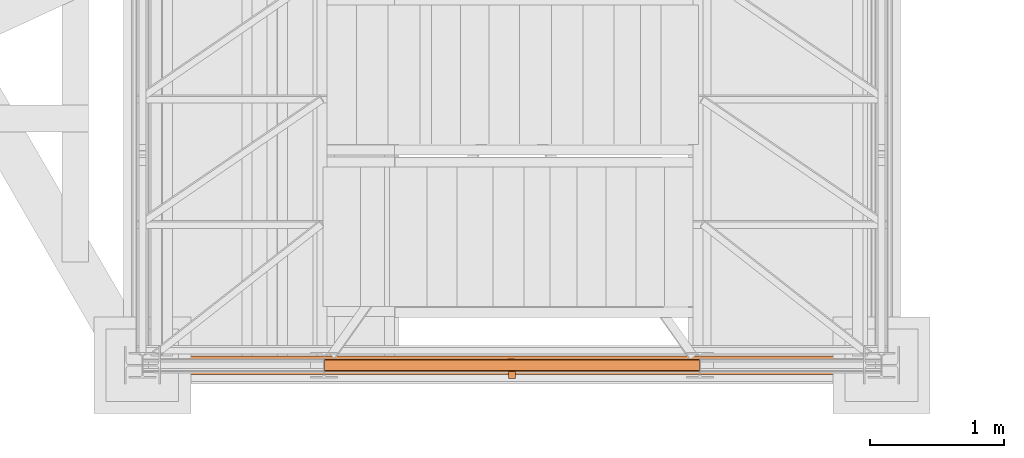
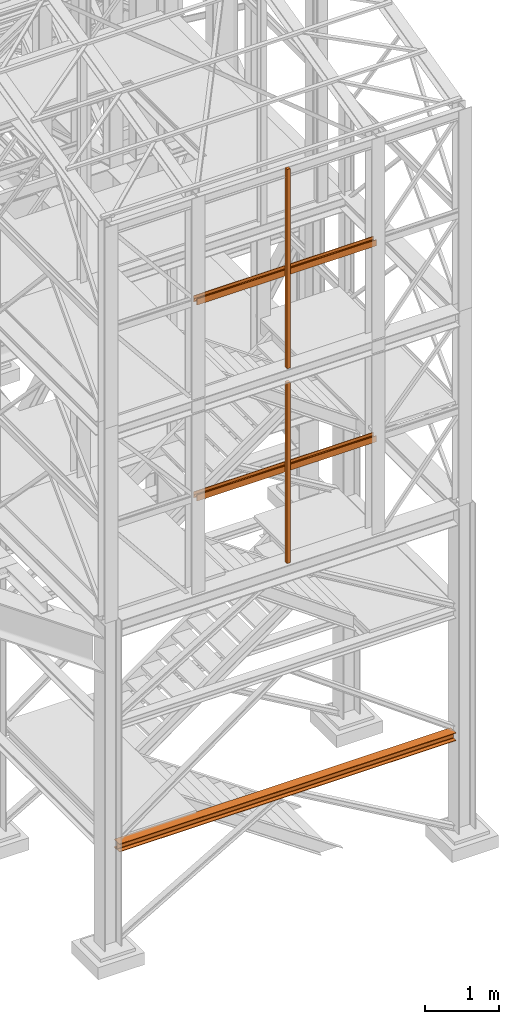
# One storey, part 40 of 208: 7 proxies.
"""IFC2X3 building model written with IfcOpenShell, lengths in millimetres."""

import ifcopenshell
import ifcopenshell.guid

model = None  # the IFC model being written
_history = None  # IfcOwnerHistory: only IFC2X3 demands one
_inside = {}  # id of a spatial element -> (the spatial element, [elements in it])
_under = {}  # id of a project, library or spatial element -> (it, [spatial elements below it])
_declared = {}  # id of a project -> (the project, [libraries it declares])
_typed = {}  # id of a type object -> (the type object, [elements of that type])
_made_of = {}  # id of a material, layer set ... -> (it, [elements and type objects made of it])


def new_model(schema):
    """Start an empty IFC model of exactly this schema.

    Asked for "IFC4X3", IfcOpenShell would pick the latest addendum, in which some entities
    have other attributes; the version numbers below select the first issue.
    IFC2X3 requires an IfcOwnerHistory on every rooted entity: one is made here for all.
    """
    global model, _history
    if schema == "IFC4X3":
        model = ifcopenshell.file(schema_version=(4, 3, 0, 0))
    else:
        model = ifcopenshell.file(schema=schema)
    _inside.clear()
    _under.clear()
    _declared.clear()
    _typed.clear()
    _made_of.clear()
    _history = None
    if model.schema == "IFC2X3":
        org = make("IfcOrganization", Name="unknown")
        user = make(
            "IfcPersonAndOrganization",
            ThePerson=make("IfcPerson", FamilyName="unknown"),
            TheOrganization=org,
        )
        app = make(
            "IfcApplication",
            ApplicationDeveloper=org,
            Version="unknown",
            ApplicationFullName="unknown",
            ApplicationIdentifier="unknown",
        )
        _history = make(
            "IfcOwnerHistory",
            OwningUser=user,
            OwningApplication=app,
            ChangeAction="ADDED",
            CreationDate=0,
        )
    return model


def make(cls, **values):
    """One entity of the class cls with the attributes given. An attribute that is None is left unset."""
    return model.create_entity(
        cls, **{name: value for name, value in values.items() if value is not None}
    )


def entity(cls, *values):
    """Any entity or typed value of the class cls, its attributes in the order of the schema. None: left unset."""
    e = model.create_entity(cls)
    for i, value in enumerate(values):
        if value is not None:
            e[i] = value
    return e


def rooted(cls, **values):
    """An entity with a GlobalId (a new one), such as an element, a storey or a relation."""
    return make(cls, GlobalId=ifcopenshell.guid.new(), OwnerHistory=_history, **values)


def si_unit(unit_type, name, prefix=None):
    """IfcSIUnit, for example si_unit("LENGTHUNIT", "METRE", prefix="MILLI")."""
    return make("IfcSIUnit", UnitType=unit_type, Prefix=prefix, Name=name)


def converted_unit(unit_type, name, factor, base, dimensions=None, offset=None):
    """IfcConversionBasedUnit, such as the inch: factor (a typed value) times the base unit."""
    return make(
        "IfcConversionBasedUnit"
        if offset is None
        else "IfcConversionBasedUnitWithOffset",
        ConversionOffset=offset,
        Dimensions=None
        if dimensions is None
        else entity("IfcDimensionalExponents", *dimensions),
        UnitType=unit_type,
        Name=name,
        ConversionFactor=make(
            "IfcMeasureWithUnit", ValueComponent=factor, UnitComponent=base
        ),
    )


def assignment(units):
    """IfcUnitAssignment: the units of a project."""
    return None if units is None else make("IfcUnitAssignment", Units=units)


def point(xyz):
    """IfcCartesianPoint."""
    return None if xyz is None else make("IfcCartesianPoint", Coordinates=xyz)


def direction(xyz):
    """IfcDirection."""
    return None if xyz is None else make("IfcDirection", DirectionRatios=xyz)


def frame(location, z_axis=None, x_axis=None):
    """IfcAxis2Placement3D, a coordinate frame: its origin and axes. An axis left out is left unset."""
    return make(
        "IfcAxis2Placement3D",
        Location=point(location),
        Axis=direction(z_axis),
        RefDirection=direction(x_axis),
    )


def origin():
    """The frame at (0, 0, 0) with its axes left unset."""
    return frame((0.0, 0.0, 0.0))


def origin_with_axes():
    """The frame at (0, 0, 0) with the z axis (0, 0, 1) and the x axis (1, 0, 0) written out."""
    return frame((0.0, 0.0, 0.0), z_axis=(0.0, 0.0, 1.0), x_axis=(1.0, 0.0, 0.0))


def place(relative_to, where):
    """IfcLocalPlacement: puts the frame where relative to a parent placement (None: the world)."""
    return make(
        "IfcLocalPlacement", PlacementRelTo=relative_to, RelativePlacement=where
    )


def context(
    kind, dimensions, precision=None, world=None, true_north=None, identifier=None
):
    """IfcGeometricRepresentationContext, for example the 3D "Model" context."""
    return make(
        "IfcGeometricRepresentationContext",
        ContextIdentifier=identifier,
        ContextType=kind,
        CoordinateSpaceDimension=dimensions,
        Precision=precision,
        WorldCoordinateSystem=world,
        TrueNorth=true_north,
    )


def subcontext(parent, identifier, kind, view, scale=None):
    """IfcGeometricRepresentationSubContext, for example "Body" below "Model"."""
    return make(
        "IfcGeometricRepresentationSubContext",
        ContextIdentifier=identifier,
        ContextType=kind,
        ParentContext=parent,
        TargetScale=scale,
        TargetView=view,
    )


def project(units=None, contexts=None):
    """IfcProject with its units and contexts."""
    return rooted(
        "IfcProject",
        Name="project",
        RepresentationContexts=contexts,
        UnitsInContext=assignment(units),
    )


def spatial(cls, under=None, at=None, **own):
    """A site, building, storey or space (cls), placed at a placement, below another one or the project."""
    s = rooted(cls, ObjectPlacement=at, **own)
    if under is not None:
        _under.setdefault(under.id(), (under, []))[1].append(s)
    return s


def faces_of(points, faces, orient=None, outer=None):
    """IfcFace entities. A face is a list of loops; a loop is a list of indices into points, from 0.

    orient and outer hold one flag for each loop. By default every Orientation is true, the
    first loop of a face is its IfcFaceOuterBound and the others are IfcFaceBound.
    """
    made = []
    for i, loops in enumerate(faces):
        bounds = []
        for j, loop in enumerate(loops):
            is_outer = j == 0 if outer is None else outer[i][j]
            bounds.append(
                make(
                    "IfcFaceOuterBound" if is_outer else "IfcFaceBound",
                    Bound=make("IfcPolyLoop", Polygon=[points[k] for k in loop]),
                    Orientation=True if orient is None else orient[i][j],
                )
            )
        made.append(make("IfcFace", Bounds=bounds))
    return made


def faceted_brep(points, faces, orient=None, outer=None, voids=None):
    """IfcFacetedBrep: a solid bounded by flat faces; with voids (closed shells), ...WithVoids."""
    shared = [point(p) for p in points]
    hull = make("IfcClosedShell", CfsFaces=faces_of(shared, faces, orient, outer))
    if voids is None:
        return make("IfcFacetedBrep", Outer=hull)
    return make(
        "IfcFacetedBrepWithVoids",
        Outer=hull,
        Voids=[
            make(cls, CfsFaces=faces_of(shared, fs, o, b)) for cls, fs, o, b in voids
        ],
    )


def shape(context_of_items, identifier, shape_type, items):
    """IfcShapeRepresentation: the items that make up one representation, for example the "Body"."""
    return make(
        "IfcShapeRepresentation",
        ContextOfItems=context_of_items,
        RepresentationIdentifier=identifier,
        RepresentationType=shape_type,
        Items=items,
    )


def made_of(thing, what):
    """Note that an element or type object is made of a material, layer set ...; save() writes the relation."""
    if what is not None:
        _made_of.setdefault(what.id(), (what, []))[1].append(thing)
    return thing


def element(
    cls,
    number,
    at=None,
    inside=None,
    cuts=None,
    type_object=None,
    material=None,
    context=None,
    identifier="Body",
    shape_type=None,
    held_by="IfcProductDefinitionShape",
    body=None,
    shapes=None,
    **own,
):
    """One element of the class cls, such as IfcWall. Its Tag is "e" and its number.

    at: its placement. inside: the storey or other place that contains it. cuts: it is an
    opening in that element (IfcRelVoidsElement). A single representation is given by context,
    identifier, shape_type and body (its items); several are given by shapes. held_by: the class
    of the entity that holds the representations. save() writes the other relations.
    """
    e = rooted(cls, Tag="e%d" % number, ObjectPlacement=at, **own)
    if body is not None:
        shapes = [shape(context, identifier, shape_type, body)]
    if shapes is not None:
        e.Representation = make(held_by, Representations=shapes)
    if inside is not None:
        _inside.setdefault(inside.id(), (inside, []))[1].append(e)
    if cuts is not None:
        rooted(
            "IfcRelVoidsElement", RelatingBuildingElement=cuts, RelatedOpeningElement=e
        )
    if type_object is not None:
        _typed.setdefault(type_object.id(), (type_object, []))[1].append(e)
    return made_of(e, material)


def aggregate(whole, parts):
    """IfcRelAggregates: a whole, such as a stair, and the parts it consists of."""
    return rooted("IfcRelAggregates", RelatingObject=whole, RelatedObjects=parts)


def save(model, path):
    """Write the relations noted so far, then the file.

    IfcRelAggregates (storeys below a building ...), IfcRelContainedInSpatialStructure (elements
    in a storey), IfcRelDefinesByType, IfcRelAssociatesMaterial and IfcRelDeclares: one each for
    every whole, place, type object, material and project.
    """
    for whole, parts in _under.values():
        aggregate(whole, parts)
    for where, things in _inside.values():
        rooted(
            "IfcRelContainedInSpatialStructure",
            RelatedElements=things,
            RelatingStructure=where,
        )
    for kind, things in _typed.values():
        rooted("IfcRelDefinesByType", RelatedObjects=things, RelatingType=kind)
    for what, things in _made_of.values():
        rooted("IfcRelAssociatesMaterial", RelatedObjects=things, RelatingMaterial=what)
    for by, libraries in _declared.values():
        rooted("IfcRelDeclares", RelatingContext=by, RelatedDefinitions=libraries)
    model.write(path)


model = new_model("IFC2X3")

# Units and contexts
model_context = context("Model", 3, precision=1e-05, world=origin())
plan_context = context("Plan", 3, precision=1e-05, world=origin())
body_context = subcontext(model_context, "Body", "Model", "MODEL_VIEW")
ifc_project = project(units=[si_unit("LENGTHUNIT", "METRE", prefix="MILLI"), converted_unit("PLANEANGLEUNIT", "DEGREE", entity("IfcPlaneAngleMeasure", 0.0174532925199433), si_unit("PLANEANGLEUNIT", "RADIAN"), dimensions=[0, 0, 0, 0, 0, 0, 0]), si_unit("AREAUNIT", "SQUARE_METRE"), si_unit("VOLUMEUNIT", "CUBIC_METRE")], contexts=[model_context, plan_context])

# Building, storey
building_placement = place(None, origin())
building = spatial("IfcBuilding", under=ifc_project, at=building_placement, CompositionType="COMPLEX")
storey_placement = place(building_placement, origin_with_axes())
storey = spatial("IfcBuildingStorey", under=building, at=storey_placement, Name="Geschoss", CompositionType="ELEMENT")

# Proxies
proxy_1_placement = place(storey_placement, frame((2551.504968595716, -25220.57439031787, 9979.990000745052), z_axis=(0.0, 0.0, 1.0), x_axis=(1.0, 0.0, 0.0)))
element("IfcBuildingElementProxy", 1, at=proxy_1_placement, inside=storey, context=body_context, shape_type="Brep", body=[
    faceted_brep([(0.01000000000021828, 8.0099999999984, 0.01000000000021828), (0.01000000000021828, 8.0099999999984, 47.51000000000022), (0.01000000000021828, 88.0099999999984, 47.51000000000022), (0.01000000000021828, 88.0099999999984, 0.01000000000021828), (0.01000000000021828, 96.0099999999984, 0.01000000000021828), (0.01000000000021828, 96.0099999999984, 100.0100000000002), (0.01000000000021828, 88.0099999999984, 100.0100000000002), (0.01000000000021828, 88.0099999999984, 52.51000000000022), (0.01000000000021828, 8.0099999999984, 52.51000000000022), (0.01000000000021828, 8.0099999999984, 100.0100000000002), (0.01000000000021828, 0.00999999999839929, 100.0100000000002), (0.01000000000021828, 0.00999999999839929, 0.01000000000021828), (0.01000000000021828, 0.00999999999839929, 0.01000000000021828), (2793.509999865888, 0.00999999999839929, 0.01000000000021828), (2793.509999865888, 8.0099999999984, 0.01000000000021828), (0.01000000000021828, 8.0099999999984, 0.01000000000021828), (0.01000000000021828, 0.00999999999839929, 100.0100000000002), (2793.509999865888, 0.00999999999839929, 100.0100000000002), (2793.509999865888, 0.00999999999839929, 0.01000000000021828), (0.01000000000021828, 0.00999999999839929, 0.01000000000021828), (0.01000000000021828, 8.0099999999984, 100.0100000000002), (2793.509999865888, 8.0099999999984, 100.0100000000002), (2793.509999865888, 0.00999999999839929, 100.0100000000002), (0.01000000000021828, 0.00999999999839929, 100.0100000000002), (0.01000000000021828, 8.0099999999984, 52.51000000000022), (2793.509999865888, 8.0099999999984, 52.51000000000022), (2793.509999865888, 8.0099999999984, 100.0100000000002), (0.01000000000021828, 8.0099999999984, 100.0100000000002), (0.01000000000021828, 88.0099999999984, 52.51000000000022), (2793.509999865888, 88.0099999999984, 52.51000000000022), (2793.509999865888, 8.0099999999984, 52.51000000000022), (0.01000000000021828, 8.0099999999984, 52.51000000000022), (0.01000000000021828, 88.0099999999984, 100.0100000000002), (2793.509999865888, 88.0099999999984, 100.0100000000002), (2793.509999865888, 88.0099999999984, 52.51000000000022), (0.01000000000021828, 88.0099999999984, 52.51000000000022), (0.01000000000021828, 96.0099999999984, 100.0100000000002), (2793.509999865888, 96.0099999999984, 100.0100000000002), (2793.509999865888, 88.0099999999984, 100.0100000000002), (0.01000000000021828, 88.0099999999984, 100.0100000000002), (0.01000000000021828, 96.0099999999984, 0.01000000000021828), (2793.509999865888, 96.0099999999984, 0.01000000000021828), (2793.509999865888, 96.0099999999984, 100.0100000000002), (0.01000000000021828, 96.0099999999984, 100.0100000000002), (0.01000000000021828, 88.0099999999984, 0.01000000000021828), (2793.509999865888, 88.0099999999984, 0.01000000000021828), (2793.509999865888, 96.0099999999984, 0.01000000000021828), (0.01000000000021828, 96.0099999999984, 0.01000000000021828), (0.01000000000021828, 88.0099999999984, 47.51000000000022), (2793.509999865888, 88.0099999999984, 47.51000000000022), (2793.509999865888, 88.0099999999984, 0.01000000000021828), (0.01000000000021828, 88.0099999999984, 0.01000000000021828), (0.01000000000021828, 8.0099999999984, 47.51000000000022), (2793.509999865888, 8.0099999999984, 47.51000000000022), (2793.509999865888, 88.0099999999984, 47.51000000000022), (0.01000000000021828, 88.0099999999984, 47.51000000000022), (0.01000000000021828, 8.0099999999984, 0.01000000000021828), (2793.509999865888, 8.0099999999984, 0.01000000000021828), (2793.509999865888, 8.0099999999984, 47.51000000000022), (0.01000000000021828, 8.0099999999984, 47.51000000000022), (2793.509999865888, 8.0099999999984, 0.01000000000021828), (2793.509999865888, 0.00999999999839929, 0.01000000000021828), (2793.509999865888, 0.00999999999839929, 100.0100000000002), (2793.509999865888, 8.0099999999984, 100.0100000000002), (2793.509999865888, 8.0099999999984, 52.51000000000022), (2793.509999865888, 88.0099999999984, 52.51000000000022), (2793.509999865888, 88.0099999999984, 100.0100000000002), (2793.509999865888, 96.0099999999984, 100.0100000000002), (2793.509999865888, 96.0099999999984, 0.01000000000021828), (2793.509999865888, 88.0099999999984, 0.01000000000021828), (2793.509999865888, 88.0099999999984, 47.51000000000022), (2793.509999865888, 8.0099999999984, 47.51000000000022)], [[[0, 1, 2, 3, 4, 5, 6, 7, 8, 9, 10, 11]], [[12, 13, 14, 15]], [[16, 17, 18, 19]], [[20, 21, 22, 23]], [[24, 25, 26, 27]], [[28, 29, 30, 31]], [[32, 33, 34, 35]], [[36, 37, 38, 39]], [[40, 41, 42, 43]], [[44, 45, 46, 47]], [[48, 49, 50, 51]], [[52, 53, 54, 55]], [[56, 57, 58, 59]], [[60, 61, 62, 63, 64, 65, 66, 67, 68, 69, 70, 71]]], orient=[[False], [False], [False], [False], [False], [False], [False], [False], [False], [False], [False], [False], [False], [False]]),
])
proxy_2_placement = place(storey_placement, frame((3923.254968156133, -25270.57439106293, 8484.990002086157), z_axis=(0.0, 0.0, 1.0), x_axis=(1.0, 0.0, 0.0)))
element("IfcBuildingElementProxy", 2, at=proxy_2_placement, inside=storey, context=body_context, shape_type="Brep", body=[
    faceted_brep([(50.01000074505828, 0.00999999999839929, 0.01000000000021828), (50.01000074505828, 50.01000074505646, 0.01000000000021828), (0.01000000000021828, 50.01000074505646, 0.01000000000021828), (0.01000000000021828, 0.00999999999839929, 0.01000000000021828), (50.01000074505828, 50.01000074505646, 3275.010003576283), (50.01000074505828, 0.00999999999839929, 3275.010003576283), (0.01000000000021828, 0.00999999999839929, 3275.010003576283), (0.01000000000021828, 50.01000074505646, 3275.010003576283), (50.01000074505828, 50.01000074505646, 0.01000000000021828), (50.01000074505828, 0.00999999999839929, 0.01000000000021828), (50.01000074505828, 0.00999999999839929, 3275.010003576283), (50.01000074505828, 50.01000074505646, 3275.010003576283), (0.01000000000021828, 50.01000074505646, 0.01000000000021828), (50.01000074505828, 50.01000074505646, 0.01000000000021828), (50.01000074505828, 50.01000074505646, 3275.010003576283), (0.01000000000021828, 50.01000074505646, 3275.010003576283), (0.01000000000021828, 0.00999999999839929, 0.01000000000021828), (0.01000000000021828, 50.01000074505646, 0.01000000000021828), (0.01000000000021828, 50.01000074505646, 3275.010003576283), (0.01000000000021828, 0.00999999999839929, 3275.010003576283), (50.01000074505828, 0.00999999999839929, 0.01000000000021828), (0.01000000000021828, 0.00999999999839929, 0.01000000000021828), (0.01000000000021828, 0.00999999999839929, 3275.010003576283), (50.01000074505828, 0.00999999999839929, 3275.010003576283)], [[[0, 1, 2, 3]], [[4, 5, 6, 7]], [[8, 9, 10, 11]], [[12, 13, 14, 15]], [[16, 17, 18, 19]], [[20, 21, 22, 23]]], orient=[[False], [False], [False], [False], [False], [False]]),
])
proxy_3_placement = place(storey_placement, frame((2551.504968595716, -25220.57439031787, 9979.990000745052), z_axis=(0.0, 0.0, 1.0), x_axis=(1.0, 0.0, 0.0)))
element("IfcBuildingElementProxy", 3, at=proxy_3_placement, inside=storey, context=body_context, shape_type="Brep", body=[
    faceted_brep([(0.01000000000021828, 8.0099999999984, 0.01000000000021828), (0.01000000000021828, 8.0099999999984, 47.51000000000022), (0.01000000000021828, 88.0099999999984, 47.51000000000022), (0.01000000000021828, 88.0099999999984, 0.01000000000021828), (0.01000000000021828, 96.0099999999984, 0.01000000000021828), (0.01000000000021828, 96.0099999999984, 100.0100000000002), (0.01000000000021828, 88.0099999999984, 100.0100000000002), (0.01000000000021828, 88.0099999999984, 52.51000000000022), (0.01000000000021828, 8.0099999999984, 52.51000000000022), (0.01000000000021828, 8.0099999999984, 100.0100000000002), (0.01000000000021828, 0.00999999999839929, 100.0100000000002), (0.01000000000021828, 0.00999999999839929, 0.01000000000021828), (0.01000000000021828, 0.00999999999839929, 0.01000000000021828), (2793.509999865888, 0.00999999999839929, 0.01000000000021828), (2793.509999865888, 8.0099999999984, 0.01000000000021828), (0.01000000000021828, 8.0099999999984, 0.01000000000021828), (0.01000000000021828, 0.00999999999839929, 100.0100000000002), (2793.509999865888, 0.00999999999839929, 100.0100000000002), (2793.509999865888, 0.00999999999839929, 0.01000000000021828), (0.01000000000021828, 0.00999999999839929, 0.01000000000021828), (0.01000000000021828, 8.0099999999984, 100.0100000000002), (2793.509999865888, 8.0099999999984, 100.0100000000002), (2793.509999865888, 0.00999999999839929, 100.0100000000002), (0.01000000000021828, 0.00999999999839929, 100.0100000000002), (0.01000000000021828, 8.0099999999984, 52.51000000000022), (2793.509999865888, 8.0099999999984, 52.51000000000022), (2793.509999865888, 8.0099999999984, 100.0100000000002), (0.01000000000021828, 8.0099999999984, 100.0100000000002), (0.01000000000021828, 88.0099999999984, 52.51000000000022), (2793.509999865888, 88.0099999999984, 52.51000000000022), (2793.509999865888, 8.0099999999984, 52.51000000000022), (0.01000000000021828, 8.0099999999984, 52.51000000000022), (0.01000000000021828, 88.0099999999984, 100.0100000000002), (2793.509999865888, 88.0099999999984, 100.0100000000002), (2793.509999865888, 88.0099999999984, 52.51000000000022), (0.01000000000021828, 88.0099999999984, 52.51000000000022), (0.01000000000021828, 96.0099999999984, 100.0100000000002), (2793.509999865888, 96.0099999999984, 100.0100000000002), (2793.509999865888, 88.0099999999984, 100.0100000000002), (0.01000000000021828, 88.0099999999984, 100.0100000000002), (0.01000000000021828, 96.0099999999984, 0.01000000000021828), (2793.509999865888, 96.0099999999984, 0.01000000000021828), (2793.509999865888, 96.0099999999984, 100.0100000000002), (0.01000000000021828, 96.0099999999984, 100.0100000000002), (0.01000000000021828, 88.0099999999984, 0.01000000000021828), (2793.509999865888, 88.0099999999984, 0.01000000000021828), (2793.509999865888, 96.0099999999984, 0.01000000000021828), (0.01000000000021828, 96.0099999999984, 0.01000000000021828), (0.01000000000021828, 88.0099999999984, 47.51000000000022), (2793.509999865888, 88.0099999999984, 47.51000000000022), (2793.509999865888, 88.0099999999984, 0.01000000000021828), (0.01000000000021828, 88.0099999999984, 0.01000000000021828), (0.01000000000021828, 8.0099999999984, 47.51000000000022), (2793.509999865888, 8.0099999999984, 47.51000000000022), (2793.509999865888, 88.0099999999984, 47.51000000000022), (0.01000000000021828, 88.0099999999984, 47.51000000000022), (0.01000000000021828, 8.0099999999984, 0.01000000000021828), (2793.509999865888, 8.0099999999984, 0.01000000000021828), (2793.509999865888, 8.0099999999984, 47.51000000000022), (0.01000000000021828, 8.0099999999984, 47.51000000000022), (2793.509999865888, 8.0099999999984, 0.01000000000021828), (2793.509999865888, 0.00999999999839929, 0.01000000000021828), (2793.509999865888, 0.00999999999839929, 100.0100000000002), (2793.509999865888, 8.0099999999984, 100.0100000000002), (2793.509999865888, 8.0099999999984, 52.51000000000022), (2793.509999865888, 88.0099999999984, 52.51000000000022), (2793.509999865888, 88.0099999999984, 100.0100000000002), (2793.509999865888, 96.0099999999984, 100.0100000000002), (2793.509999865888, 96.0099999999984, 0.01000000000021828), (2793.509999865888, 88.0099999999984, 0.01000000000021828), (2793.509999865888, 88.0099999999984, 47.51000000000022), (2793.509999865888, 8.0099999999984, 47.51000000000022)], [[[0, 1, 2, 3, 4, 5, 6, 7, 8, 9, 10, 11]], [[12, 13, 14, 15]], [[16, 17, 18, 19]], [[20, 21, 22, 23]], [[24, 25, 26, 27]], [[28, 29, 30, 31]], [[32, 33, 34, 35]], [[36, 37, 38, 39]], [[40, 41, 42, 43]], [[44, 45, 46, 47]], [[48, 49, 50, 51]], [[52, 53, 54, 55]], [[56, 57, 58, 59]], [[60, 61, 62, 63, 64, 65, 66, 67, 68, 69, 70, 71]]], orient=[[False], [False], [False], [False], [False], [False], [False], [False], [False], [False], [False], [False], [False], [False]]),
])
proxy_4_placement = place(storey_placement, frame((3923.254968156133, -25270.57439106293, 8484.990002086157), z_axis=(0.0, 0.0, 1.0), x_axis=(1.0, 0.0, 0.0)))
element("IfcBuildingElementProxy", 4, at=proxy_4_placement, inside=storey, context=body_context, shape_type="Brep", body=[
    faceted_brep([(50.01000074505828, 0.00999999999839929, 0.01000000000021828), (50.01000074505828, 50.01000074505646, 0.01000000000021828), (0.01000000000021828, 50.01000074505646, 0.01000000000021828), (0.01000000000021828, 0.00999999999839929, 0.01000000000021828), (50.01000074505828, 50.01000074505646, 3275.010003576283), (50.01000074505828, 0.00999999999839929, 3275.010003576283), (0.01000000000021828, 0.00999999999839929, 3275.010003576283), (0.01000000000021828, 50.01000074505646, 3275.010003576283), (50.01000074505828, 50.01000074505646, 0.01000000000021828), (50.01000074505828, 0.00999999999839929, 0.01000000000021828), (50.01000074505828, 0.00999999999839929, 3275.010003576283), (50.01000074505828, 50.01000074505646, 3275.010003576283), (0.01000000000021828, 50.01000074505646, 0.01000000000021828), (50.01000074505828, 50.01000074505646, 0.01000000000021828), (50.01000074505828, 50.01000074505646, 3275.010003576283), (0.01000000000021828, 50.01000074505646, 3275.010003576283), (0.01000000000021828, 0.00999999999839929, 0.01000000000021828), (0.01000000000021828, 50.01000074505646, 0.01000000000021828), (0.01000000000021828, 50.01000074505646, 3275.010003576283), (0.01000000000021828, 0.00999999999839929, 3275.010003576283), (50.01000074505828, 0.00999999999839929, 0.01000000000021828), (0.01000000000021828, 0.00999999999839929, 0.01000000000021828), (0.01000000000021828, 0.00999999999839929, 3275.010003576283), (50.01000074505828, 0.00999999999839929, 3275.010003576283)], [[[0, 1, 2, 3]], [[4, 5, 6, 7]], [[8, 9, 10, 11]], [[12, 13, 14, 15]], [[16, 17, 18, 19]], [[20, 21, 22, 23]]], orient=[[False], [False], [False], [False], [False], [False]]),
])
proxy_5_placement = place(storey_placement, frame((2551.504968595721, -25220.57438993343, 6759.989999254943), z_axis=(0.0, 0.0, 1.0), x_axis=(1.0, 0.0, 0.0)))
element("IfcBuildingElementProxy", 5, at=proxy_5_placement, inside=storey, context=body_context, shape_type="Brep", body=[
    faceted_brep([(0.01000000000021828, 88.0099999999984, 0.01000000000021828), (0.01000000000021828, 96.0099999999984, 0.01000000000021828), (0.01000000000021828, 96.0099999999984, 100.0100000000002), (0.01000000000021828, 88.0099999999984, 100.0100000000002), (0.01000000000021828, 88.0099999999984, 52.51000000000022), (0.01000000000021828, 8.0099999999984, 52.51000000000022), (0.01000000000021828, 8.0099999999984, 100.0100000000002), (0.01000000000021828, 0.00999999999839929, 100.0100000000002), (0.01000000000021828, 0.00999999999839929, 0.01000000000021828), (0.01000000000021828, 8.0099999999984, 0.01000000000021828), (0.01000000000021828, 8.0099999999984, 47.51000000000022), (0.01000000000021828, 88.0099999999984, 47.51000000000022), (0.01000000000021828, 96.0099999999984, 0.01000000000021828), (0.01000000000021828, 88.0099999999984, 0.01000000000021828), (2793.509999865889, 88.0099999999984, 0.01000000000021828), (2793.509999865889, 96.0099999999984, 0.01000000000021828), (0.01000000000021828, 96.0099999999984, 100.0100000000002), (0.01000000000021828, 96.0099999999984, 0.01000000000021828), (2793.509999865889, 96.0099999999984, 0.01000000000021828), (2793.509999865889, 96.0099999999984, 100.0100000000002), (0.01000000000021828, 88.0099999999984, 100.0100000000002), (0.01000000000021828, 96.0099999999984, 100.0100000000002), (2793.509999865889, 96.0099999999984, 100.0100000000002), (2793.509999865889, 88.0099999999984, 100.0100000000002), (0.01000000000021828, 88.0099999999984, 52.51000000000022), (0.01000000000021828, 88.0099999999984, 100.0100000000002), (2793.509999865889, 88.0099999999984, 100.0100000000002), (2793.509999865889, 88.0099999999984, 52.51000000000022), (0.01000000000021828, 8.0099999999984, 52.51000000000022), (0.01000000000021828, 88.0099999999984, 52.51000000000022), (2793.509999865889, 88.0099999999984, 52.51000000000022), (2793.509999865889, 8.0099999999984, 52.51000000000022), (0.01000000000021828, 8.0099999999984, 100.0100000000002), (0.01000000000021828, 8.0099999999984, 52.51000000000022), (2793.509999865889, 8.0099999999984, 52.51000000000022), (2793.509999865889, 8.0099999999984, 100.0100000000002), (0.01000000000021828, 0.00999999999839929, 100.0100000000002), (0.01000000000021828, 8.0099999999984, 100.0100000000002), (2793.509999865889, 8.0099999999984, 100.0100000000002), (2793.509999865889, 0.00999999999839929, 100.0100000000002), (0.01000000000021828, 0.00999999999839929, 0.01000000000021828), (0.01000000000021828, 0.00999999999839929, 100.0100000000002), (2793.509999865889, 0.00999999999839929, 100.0100000000002), (2793.509999865889, 0.00999999999839929, 0.01000000000021828), (0.01000000000021828, 8.0099999999984, 0.01000000000021828), (0.01000000000021828, 0.00999999999839929, 0.01000000000021828), (2793.509999865889, 0.00999999999839929, 0.01000000000021828), (2793.509999865889, 8.0099999999984, 0.01000000000021828), (0.01000000000021828, 8.0099999999984, 47.51000000000022), (0.01000000000021828, 8.0099999999984, 0.01000000000021828), (2793.509999865889, 8.0099999999984, 0.01000000000021828), (2793.509999865889, 8.0099999999984, 47.51000000000022), (0.01000000000021828, 88.0099999999984, 47.51000000000022), (0.01000000000021828, 8.0099999999984, 47.51000000000022), (2793.509999865889, 8.0099999999984, 47.51000000000022), (2793.509999865889, 88.0099999999984, 47.51000000000022), (0.01000000000021828, 88.0099999999984, 0.01000000000021828), (0.01000000000021828, 88.0099999999984, 47.51000000000022), (2793.509999865889, 88.0099999999984, 47.51000000000022), (2793.509999865889, 88.0099999999984, 0.01000000000021828), (2793.509999865889, 88.0099999999984, 0.01000000000021828), (2793.509999865889, 88.0099999999984, 47.51000000000022), (2793.509999865889, 8.0099999999984, 47.51000000000022), (2793.509999865889, 8.0099999999984, 0.01000000000021828), (2793.509999865889, 0.00999999999839929, 0.01000000000021828), (2793.509999865889, 0.00999999999839929, 100.0100000000002), (2793.509999865889, 8.0099999999984, 100.0100000000002), (2793.509999865889, 8.0099999999984, 52.51000000000022), (2793.509999865889, 88.0099999999984, 52.51000000000022), (2793.509999865889, 88.0099999999984, 100.0100000000002), (2793.509999865889, 96.0099999999984, 100.0100000000002), (2793.509999865889, 96.0099999999984, 0.01000000000021828)], [[[0, 1, 2, 3, 4, 5, 6, 7, 8, 9, 10, 11]], [[12, 13, 14, 15]], [[16, 17, 18, 19]], [[20, 21, 22, 23]], [[24, 25, 26, 27]], [[28, 29, 30, 31]], [[32, 33, 34, 35]], [[36, 37, 38, 39]], [[40, 41, 42, 43]], [[44, 45, 46, 47]], [[48, 49, 50, 51]], [[52, 53, 54, 55]], [[56, 57, 58, 59]], [[60, 61, 62, 63, 64, 65, 66, 67, 68, 69, 70, 71]]], orient=[[False], [False], [False], [False], [False], [False], [False], [False], [False], [False], [False], [False], [False], [False]]),
])
proxy_6_placement = place(storey_placement, frame((3923.254968156136, -25270.57439067849, 5284.990005364416), z_axis=(0.0, 0.0, 1.0), x_axis=(1.0, 0.0, 0.0)))
element("IfcBuildingElementProxy", 6, at=proxy_6_placement, inside=storey, context=body_context, shape_type="Brep", body=[
    faceted_brep([(50.01000074505828, 0.00999999999839929, 0.009999999999308784), (50.01000074505828, 50.01000074505646, 0.009999999999308784), (0.01000000000021828, 50.01000074505646, 0.009999999999308784), (0.01000000000021828, 0.00999999999839929, 0.009999999999308784), (50.01000074505828, 50.01000074505646, 2970.00999254942), (50.01000074505828, 0.00999999999839929, 2970.00999254942), (0.01000000000021828, 0.00999999999839929, 2970.00999254942), (0.01000000000021828, 50.01000074505646, 2970.00999254942), (50.01000074505828, 50.01000074505646, 0.009999999999308784), (50.01000074505828, 0.00999999999839929, 0.009999999999308784), (50.01000074505828, 0.00999999999839929, 2970.00999254942), (50.01000074505828, 50.01000074505646, 2970.00999254942), (0.01000000000021828, 50.01000074505646, 0.009999999999308784), (50.01000074505828, 50.01000074505646, 0.009999999999308784), (50.01000074505828, 50.01000074505646, 2970.00999254942), (0.01000000000021828, 50.01000074505646, 2970.00999254942), (0.01000000000021828, 0.00999999999839929, 0.009999999999308784), (0.01000000000021828, 50.01000074505646, 0.009999999999308784), (0.01000000000021828, 50.01000074505646, 2970.00999254942), (0.01000000000021828, 0.00999999999839929, 2970.00999254942), (50.01000074505828, 0.00999999999839929, 0.009999999999308784), (0.01000000000021828, 0.00999999999839929, 0.009999999999308784), (0.01000000000021828, 0.00999999999839929, 2970.00999254942), (50.01000074505828, 0.00999999999839929, 2970.00999254942)], [[[0, 1, 2, 3]], [[4, 5, 6, 7]], [[8, 9, 10, 11]], [[12, 13, 14, 15]], [[16, 17, 18, 19]], [[20, 21, 22, 23]]], orient=[[False], [False], [False], [False], [False], [False]]),
])
proxy_7_placement = place(storey_placement, frame((1333.254973893083, -25242.57439061591, 1433.489998909946), z_axis=(0.0, 0.0, 1.0), x_axis=(1.0, 0.0, 0.0)))
element("IfcBuildingElementProxy", 7, at=proxy_7_placement, inside=storey, context=body_context, shape_type="Brep", body=[
    faceted_brep([(0.01000000000021828, 0.01000000000567525, 8.510002324581137), (0.01000000000021828, 0.01000000000567525, 0.009999999999990905), (0.01000000000021828, 140.0100005960521, 0.009999999999990905), (0.01000000000021828, 140.0100005960521, 8.510002324581137), (0.01000000000021828, 84.76000038743587, 8.510002324581137), (0.01000000000021828, 78.54945996612878, 9.753034839630118), (0.01000000000021828, 74.00303279817672, 14.2994648015499), (0.01000000000021828, 72.76000051595838, 20.51000429153442), (0.01000000000021828, 72.76000051595838, 112.5100007450581), (0.01000000000021828, 74.00303279817672, 118.7205402350426), (0.01000000000021828, 78.54945996612878, 123.2669664716721), (0.01000000000021828, 84.76000038743587, 124.509998986721), (0.01000000000021828, 140.0100005960521, 124.509998986721), (0.01000000000021828, 140.0100005960521, 133.0100013113022), (0.01000000000021828, 0.01000000000567525, 133.0100013113022), (0.01000000000021828, 0.01000000000567525, 124.509998986721), (0.01000000000021828, 55.26000020862193, 124.509998986721), (0.01000000000021828, 61.47054062992902, 123.2669664716721), (0.01000000000021828, 66.01696779788108, 118.7205402350426), (0.01000000000021828, 67.26000008009942, 112.5100007450581), (0.01000000000021828, 67.26000008009942, 20.51000429153442), (0.01000000000021828, 66.01696779788108, 14.2994648015499), (0.01000000000021828, 61.47054062992902, 9.753034839630118), (0.01000000000021828, 55.26000020862193, 8.510002324581137), (0.01000000000021828, 0.01000000000567525, 0.009999999999990905), (0.01000000000021828, 0.01000000000567525, 8.510002324581137), (5230.009989271167, 0.01000000000203727, 8.510002324581137), (5230.009989271167, 0.01000000000203727, 0.009999999999990905), (0.01000000000021828, 140.0100005960521, 0.009999999999990905), (0.01000000000021828, 0.01000000000567525, 0.009999999999990905), (5230.009989271167, 0.01000000000203727, 0.009999999999990905), (5230.009989271167, 140.0100005960485, 0.009999999999990905), (0.01000000000021828, 140.0100005960521, 8.510002324581137), (0.01000000000021828, 140.0100005960521, 0.009999999999990905), (5230.009989271167, 140.0100005960485, 0.009999999999990905), (5230.009989271167, 140.0100005960485, 8.510002324581137), (0.01000000000021828, 84.76000038743587, 8.510002324581137), (0.01000000000021828, 140.0100005960521, 8.510002324581137), (5230.009989271167, 140.0100005960485, 8.510002324581137), (5230.009989271167, 84.76000038743223, 8.510002324581137), (0.01000000000021828, 78.54945996612878, 9.753034839630118), (0.01000000000021828, 84.76000038743587, 8.510002324581137), (5230.009989271167, 84.76000038743223, 8.510002324581137), (5230.009989271167, 78.54945996612514, 9.753034839630118), (0.01000000000021828, 74.00303279817672, 14.2994648015499), (0.01000000000021828, 78.54945996612878, 9.753034839630118), (5230.009989271167, 78.54945996612514, 9.753034839630118), (5230.009989271167, 74.00303279817308, 14.2994648015499), (0.01000000000021828, 72.76000051595838, 20.51000429153442), (0.01000000000021828, 74.00303279817672, 14.2994648015499), (5230.009989271167, 74.00303279817308, 14.2994648015499), (5230.009989271167, 72.76000051595474, 20.51000429153442), (0.01000000000021828, 72.76000051595838, 112.5100007450581), (0.01000000000021828, 72.76000051595838, 20.51000429153442), (5230.009989271167, 72.76000051595474, 20.51000429153442), (5230.009989271167, 72.76000051595474, 112.5100007450581), (0.01000000000021828, 74.00303279817672, 118.7205402350426), (0.01000000000021828, 72.76000051595838, 112.5100007450581), (5230.009989271167, 72.76000051595474, 112.5100007450581), (5230.009989271167, 74.00303279817308, 118.7205402350426), (0.01000000000021828, 78.54945996612878, 123.2669664716721), (0.01000000000021828, 74.00303279817672, 118.7205402350426), (5230.009989271167, 74.00303279817308, 118.7205402350426), (5230.009989271167, 78.54945996612514, 123.2669664716721), (0.01000000000021828, 84.76000038743587, 124.509998986721), (0.01000000000021828, 78.54945996612878, 123.2669664716721), (5230.009989271167, 78.54945996612514, 123.2669664716721), (5230.009989271167, 84.76000038743223, 124.509998986721), (0.01000000000021828, 140.0100005960521, 124.509998986721), (0.01000000000021828, 84.76000038743587, 124.509998986721), (5230.009989271167, 84.76000038743223, 124.509998986721), (5230.009989271167, 140.0100005960485, 124.509998986721), (0.01000000000021828, 140.0100005960521, 133.0100013113022), (0.01000000000021828, 140.0100005960521, 124.509998986721), (5230.009989271167, 140.0100005960485, 124.509998986721), (5230.009989271167, 140.0100005960485, 133.0100013113022), (0.01000000000021828, 0.01000000000567525, 133.0100013113022), (0.01000000000021828, 140.0100005960521, 133.0100013113022), (5230.009989271167, 140.0100005960485, 133.0100013113022), (5230.009989271167, 0.01000000000203727, 133.0100013113022), (0.01000000000021828, 0.01000000000567525, 124.509998986721), (0.01000000000021828, 0.01000000000567525, 133.0100013113022), (5230.009989271167, 0.01000000000203727, 133.0100013113022), (5230.009989271167, 0.01000000000203727, 124.509998986721), (0.01000000000021828, 55.26000020862193, 124.509998986721), (0.01000000000021828, 0.01000000000567525, 124.509998986721), (5230.009989271167, 0.01000000000203727, 124.509998986721), (5230.009989271167, 55.26000020861829, 124.509998986721), (0.01000000000021828, 61.47054062992902, 123.2669664716721), (0.01000000000021828, 55.26000020862193, 124.509998986721), (5230.009989271167, 55.26000020861829, 124.509998986721), (5230.009989271167, 61.47054062992538, 123.2669664716721), (0.01000000000021828, 66.01696779788108, 118.7205402350426), (0.01000000000021828, 61.47054062992902, 123.2669664716721), (5230.009989271167, 61.47054062992538, 123.2669664716721), (5230.009989271167, 66.01696779787744, 118.7205402350426), (0.01000000000021828, 67.26000008009942, 112.5100007450581), (0.01000000000021828, 66.01696779788108, 118.7205402350426), (5230.009989271167, 66.01696779787744, 118.7205402350426), (5230.009989271167, 67.26000008009578, 112.5100007450581), (0.01000000000021828, 67.26000008009942, 20.51000429153442), (0.01000000000021828, 67.26000008009942, 112.5100007450581), (5230.009989271167, 67.26000008009578, 112.5100007450581), (5230.009989271167, 67.26000008009578, 20.51000429153442), (0.01000000000021828, 66.01696779788108, 14.2994648015499), (0.01000000000021828, 67.26000008009942, 20.51000429153442), (5230.009989271167, 67.26000008009578, 20.51000429153442), (5230.009989271167, 66.01696779787744, 14.2994648015499), (0.01000000000021828, 61.47054062992902, 9.753034839630118), (0.01000000000021828, 66.01696779788108, 14.2994648015499), (5230.009989271167, 66.01696779787744, 14.2994648015499), (5230.009989271167, 61.47054062992538, 9.753034839630118), (0.01000000000021828, 55.26000020862193, 8.510002324581137), (0.01000000000021828, 61.47054062992902, 9.753034839630118), (5230.009989271167, 61.47054062992538, 9.753034839630118), (5230.009989271167, 55.26000020861829, 8.510002324581137), (0.01000000000021828, 0.01000000000567525, 8.510002324581137), (0.01000000000021828, 55.26000020862193, 8.510002324581137), (5230.009989271167, 55.26000020861829, 8.510002324581137), (5230.009989271167, 0.01000000000203727, 8.510002324581137), (5230.009989271167, 0.01000000000203727, 8.510002324581137), (5230.009989271167, 55.26000020861829, 8.510002324581137), (5230.009989271167, 61.47054062992538, 9.753034839630118), (5230.009989271167, 66.01696779787744, 14.2994648015499), (5230.009989271167, 67.26000008009578, 20.51000429153442), (5230.009989271167, 67.26000008009578, 112.5100007450581), (5230.009989271167, 66.01696779787744, 118.7205402350426), (5230.009989271167, 61.47054062992538, 123.2669664716721), (5230.009989271167, 55.26000020861829, 124.509998986721), (5230.009989271167, 0.01000000000203727, 124.509998986721), (5230.009989271167, 0.01000000000203727, 133.0100013113022), (5230.009989271167, 140.0100005960485, 133.0100013113022), (5230.009989271167, 140.0100005960485, 124.509998986721), (5230.009989271167, 84.76000038743223, 124.509998986721), (5230.009989271167, 78.54945996612514, 123.2669664716721), (5230.009989271167, 74.00303279817308, 118.7205402350426), (5230.009989271167, 72.76000051595474, 112.5100007450581), (5230.009989271167, 72.76000051595474, 20.51000429153442), (5230.009989271167, 74.00303279817308, 14.2994648015499), (5230.009989271167, 78.54945996612514, 9.753034839630118), (5230.009989271167, 84.76000038743223, 8.510002324581137), (5230.009989271167, 140.0100005960485, 8.510002324581137), (5230.009989271167, 140.0100005960485, 0.009999999999990905), (5230.009989271167, 0.01000000000203727, 0.009999999999990905)], [[[0, 1, 2, 3, 4, 5, 6, 7, 8, 9, 10, 11, 12, 13, 14, 15, 16, 17, 18, 19, 20, 21, 22, 23]], [[24, 25, 26, 27]], [[28, 29, 30, 31]], [[32, 33, 34, 35]], [[36, 37, 38, 39]], [[40, 41, 42, 43]], [[44, 45, 46, 47]], [[48, 49, 50, 51]], [[52, 53, 54, 55]], [[56, 57, 58, 59]], [[60, 61, 62, 63]], [[64, 65, 66, 67]], [[68, 69, 70, 71]], [[72, 73, 74, 75]], [[76, 77, 78, 79]], [[80, 81, 82, 83]], [[84, 85, 86, 87]], [[88, 89, 90, 91]], [[92, 93, 94, 95]], [[96, 97, 98, 99]], [[100, 101, 102, 103]], [[104, 105, 106, 107]], [[108, 109, 110, 111]], [[112, 113, 114, 115]], [[116, 117, 118, 119]], [[120, 121, 122, 123, 124, 125, 126, 127, 128, 129, 130, 131, 132, 133, 134, 135, 136, 137, 138, 139, 140, 141, 142, 143]]], orient=[[False], [False], [False], [False], [False], [False], [False], [False], [False], [False], [False], [False], [False], [False], [False], [False], [False], [False], [False], [False], [False], [False], [False], [False], [False], [False]]),
])

save(model, "model.ifc")
